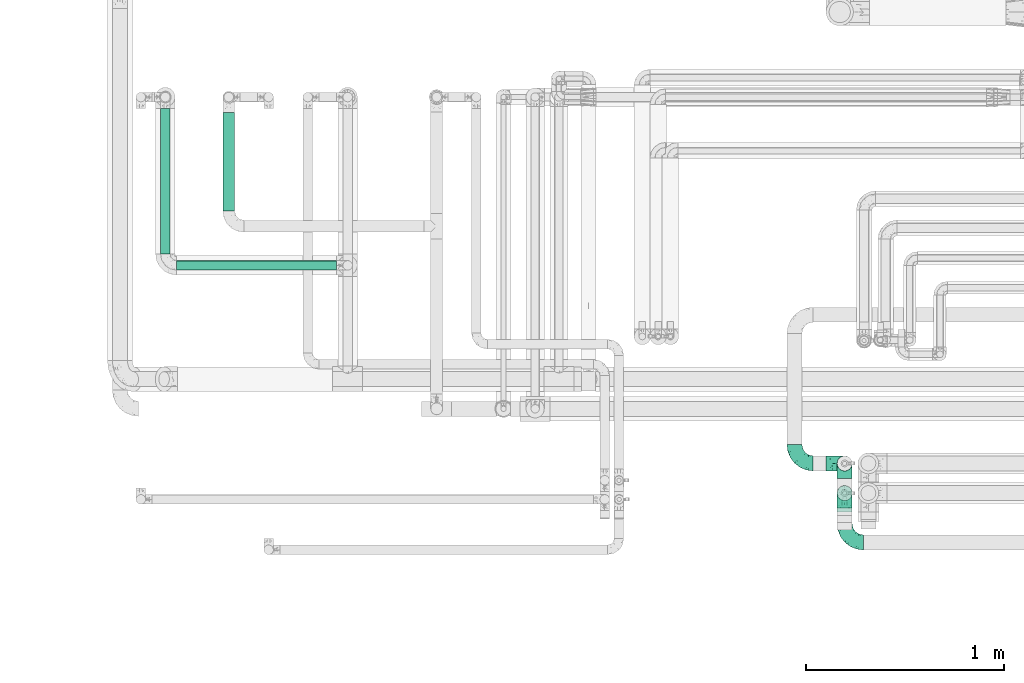
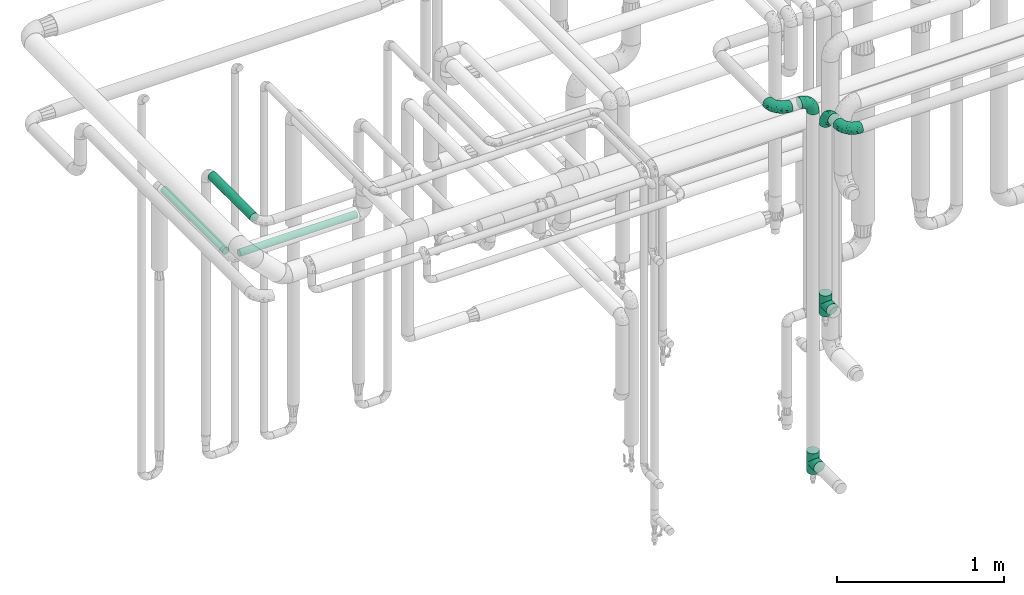
# One storey, part 694 of 827: 6 flow fittings, 3 flow segments.
"""IFC2X3 building model written with IfcOpenShell, lengths in millimetres."""

from ifc_helpers import new_model, entity, si_unit, converted_unit, derived_unit, direction, frame, origin, origin_2d_with_axis, place, context, subcontext, project, spatial, circle, extrude, faceted_brep, source, transform, mapped, material, type_object, type_shapes, element, save


model = new_model("IFC2X3")

# Units and contexts
model_context = context("Model", 3, precision=0.01, world=origin(), true_north=direction((6.12303176911189e-17, 1.0)))
body_context = subcontext(model_context, "Body", "Model", "MODEL_VIEW")
ifc_project = project(units=[si_unit("LENGTHUNIT", "METRE", prefix="MILLI"), si_unit("AREAUNIT", "SQUARE_METRE"), si_unit("VOLUMEUNIT", "CUBIC_METRE"), converted_unit("PLANEANGLEUNIT", "DEGREE", entity("IfcRatioMeasure", 0.0174532925199433), si_unit("PLANEANGLEUNIT", "RADIAN"), dimensions=[0, 0, 0, 0, 0, 0, 0]), si_unit("MASSUNIT", "GRAM", prefix="KILO"), derived_unit("MASSDENSITYUNIT", [(si_unit("MASSUNIT", "GRAM", prefix="KILO"), 1), (si_unit("LENGTHUNIT", "METRE"), -3)]), derived_unit("MOMENTOFINERTIAUNIT", [(si_unit("LENGTHUNIT", "METRE"), 4)]), si_unit("TIMEUNIT", "SECOND"), si_unit("FREQUENCYUNIT", "HERTZ"), si_unit("THERMODYNAMICTEMPERATUREUNIT", "DEGREE_CELSIUS"), derived_unit("THERMALTRANSMITTANCEUNIT", [(si_unit("MASSUNIT", "GRAM", prefix="KILO"), 1), (si_unit("THERMODYNAMICTEMPERATUREUNIT", "KELVIN"), -1), (si_unit("TIMEUNIT", "SECOND"), -3)]), derived_unit("VOLUMETRICFLOWRATEUNIT", [(si_unit("LENGTHUNIT", "METRE"), 3), (si_unit("TIMEUNIT", "SECOND"), -1)]), derived_unit("MASSFLOWRATEUNIT", [(si_unit("MASSUNIT", "GRAM", prefix="KILO"), 1), (si_unit("TIMEUNIT", "SECOND"), -1)]), derived_unit("ROTATIONALFREQUENCYUNIT", [(si_unit("TIMEUNIT", "SECOND"), -1)]), si_unit("ELECTRICCURRENTUNIT", "AMPERE"), si_unit("ELECTRICVOLTAGEUNIT", "VOLT"), si_unit("POWERUNIT", "WATT"), si_unit("FORCEUNIT", "NEWTON", prefix="KILO"), si_unit("ILLUMINANCEUNIT", "LUX"), si_unit("LUMINOUSFLUXUNIT", "LUMEN"), si_unit("LUMINOUSINTENSITYUNIT", "CANDELA"), derived_unit("USERDEFINED", [(si_unit("MASSUNIT", "GRAM", prefix="KILO"), -1), (si_unit("LENGTHUNIT", "METRE"), -2), (si_unit("TIMEUNIT", "SECOND"), 3), (si_unit("LUMINOUSFLUXUNIT", "LUMEN"), 1)]), derived_unit("LINEARVELOCITYUNIT", [(si_unit("LENGTHUNIT", "METRE"), 1), (si_unit("TIMEUNIT", "SECOND"), -1)]), si_unit("PRESSUREUNIT", "PASCAL"), derived_unit("USERDEFINED", [(si_unit("LENGTHUNIT", "METRE"), -2), (si_unit("MASSUNIT", "GRAM", prefix="KILO"), 1), (si_unit("TIMEUNIT", "SECOND"), -2)]), derived_unit("LINEARFORCEUNIT", [(si_unit("MASSUNIT", "GRAM", prefix="KILO"), 1), (si_unit("LENGTHUNIT", "METRE"), 1), (si_unit("TIMEUNIT", "SECOND"), -2), (si_unit("LENGTHUNIT", "METRE"), -1)]), derived_unit("PLANARFORCEUNIT", [(si_unit("MASSUNIT", "GRAM", prefix="KILO"), 1), (si_unit("LENGTHUNIT", "METRE"), 1), (si_unit("TIMEUNIT", "SECOND"), -2), (si_unit("LENGTHUNIT", "METRE"), -2)])], contexts=[model_context])

# Site, building, storey
site_placement = place(None, origin())
site = spatial("IfcSite", under=ifc_project, at=site_placement, CompositionType="ELEMENT")
building_placement = place(site_placement, origin())
building = spatial("IfcBuilding", under=site, at=building_placement, CompositionType="ELEMENT")
storey_placement = place(building_placement, frame((0.0, 0.0, 28200.0)))
storey = spatial("IfcBuildingStorey", under=building, at=storey_placement, Name="08", CompositionType="ELEMENT", Elevation=28200.0)

# Flow segments
pipe_segment_type = type_object("IfcPipeSegmentType", PredefinedType="NOTDEFINED")
flow_segment_1_placement = place(storey_placement, frame((52487.79, 16922.5, 2466.57)))
element("IfcFlowSegment", 1, at=flow_segment_1_placement, inside=storey, type_object=pipe_segment_type, context=body_context, shape_type="SweptSolid", body=[
    extrude(circle(Radius=30.0, at=origin_2d_with_axis()), frame((31.6, 0.0, 31.6), z_axis=(0.0, 1.0, 0.0), x_axis=(-1.0, 0.0, 0.0)), (0.0, 0.0, 1.0), 500.537174621597),
])
flow_segment_2_placement = place(storey_placement, frame((52172.68, 16705.39, 2472.57)))
element("IfcFlowSegment", 2, at=flow_segment_2_placement, inside=storey, type_object=pipe_segment_type, context=body_context, shape_type="SweptSolid", body=[
    extrude(circle(Radius=24.0, at=origin_2d_with_axis()), frame((25.6, 0.0, 25.6), z_axis=(0.0, 1.0, 0.0), x_axis=(-1.0, 0.0, 0.0)), (0.0, 0.0, 1.0), 737.613736356019),
])
flow_segment_3_placement = place(storey_placement, frame((52255.28, 16622.79, 2472.57)))
element("IfcFlowSegment", 3, at=flow_segment_3_placement, inside=storey, type_object=pipe_segment_type, context=body_context, shape_type="SweptSolid", body=[
    extrude(circle(Radius=24.0, at=origin_2d_with_axis()), frame((0.0, 25.6, 25.6), z_axis=(1.0, 0.0, 0.0), x_axis=(0.0, -1.0, 0.0)), (0.0, 0.0, 1.0), 808.780981573714),
])

# Flow fittings
ifc_material = material()
pipe_fitting_type_1 = type_object("IfcPipeFittingType", Name="ADSK_1", PredefinedType="NOTDEFINED", material=ifc_material)
shared_shape_1 = source(origin(), body_context, "Body", "Brep", [
    faceted_brep([(-95.0, 19.02, -32.95), (-95.0, 9.85, -36.75), (-95.0, 0.0, -38.05), (-95.0, -9.85, -36.75), (-95.0, -19.03, -32.95), (-95.0, -26.91, -26.91), (-95.0, -32.95, -19.03), (-95.0, -36.75, -9.85), (-95.0, -38.05, 0.0), (-95.0, -36.75, 9.85), (-95.0, -32.95, 19.02), (-95.0, -26.91, 26.91), (-95.0, -19.03, 32.95), (-95.0, -9.85, 36.75), (-95.0, 0.0, 38.05), (-95.0, 9.85, 36.75), (-95.0, 19.02, 32.95), (-95.0, 26.91, 26.91), (-95.0, 32.95, 19.02), (-95.0, 36.75, 9.85), (-95.0, 38.05, 0.0), (-95.0, 36.75, -9.85), (-95.0, 32.95, -19.03), (-95.0, 26.91, -26.91), (0.0, 95.0, -38.05), (-9.85, 95.0, -36.75), (-19.02, 95.0, -32.95), (-26.91, 95.0, -26.91), (-32.95, 95.0, -19.03), (-36.75, 95.0, -9.85), (-38.05, 95.0, 0.0), (-36.75, 95.0, 9.85), (-32.95, 95.0, 19.02), (-26.91, 95.0, 26.91), (-19.02, 95.0, 32.95), (-9.85, 95.0, 36.75), (0.0, 95.0, 38.05), (9.85, 95.0, 36.75), (19.03, 95.0, 32.95), (26.91, 95.0, 26.91), (32.95, 95.0, 19.02), (36.75, 95.0, 9.85), (38.05, 95.0, 0.0), (36.75, 95.0, -9.85), (32.95, 95.0, -19.03), (26.91, 95.0, -26.91), (19.03, 95.0, -32.95), (9.85, 95.0, -36.75), (-7.99, -4.96, 6.3), (-0.92, 0.92, 0.0), (4.62, 8.1, 8.01), (-76.19, -35.57, 0.0), (-64.32, -32.32, 12.43), (20.51, 62.45, 28.68), (-60.56, -33.52, 0.0), (-70.4, -13.47, 34.42), (-39.61, -5.88, 32.32), (-49.6, 2.07, 37.1), (-70.34, -28.81, 21.71), (14.64, 40.81, 26.5), (5.88, 39.61, 32.32), (3.59, 20.77, 25.31), (-40.45, 68.06, 16.75), (-62.45, -20.51, 28.68), (-44.52, -26.87, 0.0), (-28.47, -20.22, 0.0), (-26.43, -17.83, 8.75), (-76.1, 39.63, 10.76), (-72.74, 37.58, 18.19), (-60.35, 46.18, 14.61), (-13.4, 13.4, 32.12), (-20.77, -3.59, 25.31), (-14.66, 81.47, 35.56), (-6.22, 71.26, 37.92), (-57.5, 42.48, 22.79), (-15.0, 34.74, 37.7), (-27.1, 12.08, 36.05), (-9.2, 28.81, 35.63), (-79.98, 23.7, 30.95), (-73.68, -4.3, 37.48), (-30.74, 21.67, 37.97), (-62.36, 47.59, 6.79), (-72.71, 32.83, 24.69), (-67.42, 7.02, 37.95), (-32.13, 75.27, 24.51), (-43.46, 51.47, 26.26), (-24.98, 73.15, 31.29), (20.59, 41.28, 19.85), (7.79, 16.09, 15.86), (-73.21, 42.39, 0.0), (-54.73, 54.73, 0.0), (-73.44, 15.79, 35.79), (-5.94, 4.32, 20.43), (28.81, 70.34, 21.71), (32.32, 64.32, 12.43), (-53.59, 26.2, 35.09), (-52.02, 19.31, 37.21), (21.38, 33.53, 10.34), (26.87, 44.52, 0.0), (-48.28, 12.14, 38.05), (4.3, 73.68, 37.48), (-44.08, -25.52, 12.79), (-41.28, -20.59, 19.85), (35.57, 76.19, 0.0), (-47.26, 54.3, 20.18), (-47.4, 61.99, 8.58), (-42.39, 73.21, 0.0), (-39.67, 78.86, 7.21), (-45.69, 36.84, 33.11), (-32.83, 50.13, 33.35), (13.47, 70.4, 34.42), (-18.25, 63.73, 36.07), (-40.63, -13.75, 27.22), (-16.63, 46.37, 37.95), (-53.47, 38.79, 28.59), (-26.07, 48.54, 36.15), (-34.51, 34.51, 36.86), (-2.07, 49.6, 37.1), (-22.79, -10.49, 19.23), (-61.73, 28.67, 31.87), (9.65, 14.7, 0.0), (20.22, 28.47, 0.0), (33.52, 60.56, 0.0), (-11.42, -5.44, 13.25), (-14.7, -9.65, 0.0), (-81.47, 14.66, -35.56), (-62.45, -20.51, -28.68), (-71.26, 6.22, -37.92), (-75.27, 32.13, -24.51), (-73.15, 24.98, -31.29), (13.47, 70.4, -34.42), (5.88, 39.61, -32.32), (-2.07, 49.6, -37.1), (-78.86, 39.67, -7.21), (-70.4, -13.47, -34.42), (-39.61, -5.88, -32.32), (-61.99, 47.4, -8.58), (32.32, 64.32, -12.43), (28.81, 70.34, -21.71), (-63.73, 18.25, -36.07), (-50.13, 32.83, -33.35), (4.3, 73.68, -37.48), (-7.02, 67.42, -37.95), (-39.63, 76.1, -10.76), (-46.18, 60.35, -14.61), (-47.59, 62.36, -6.79), (-64.32, -32.32, -12.43), (-26.2, 53.59, -35.09), (-15.79, 73.44, -35.79), (-19.31, 52.02, -37.21), (-37.58, 72.74, -18.19), (-70.34, -28.81, -21.71), (-42.48, 57.5, -22.79), (-38.79, 53.47, -28.59), (-51.47, 43.46, -26.26), (-32.83, 72.71, -24.69), (-46.37, 16.63, -37.95), (-73.68, -4.3, -37.48), (-41.28, -20.59, -19.85), (-44.08, -25.52, -12.79), (13.75, 40.63, -27.22), (20.51, 62.45, -28.68), (-68.06, 40.45, -16.75), (-54.3, 47.26, -20.18), (-12.14, 48.28, -38.05), (-21.67, 30.74, -37.97), (-36.84, 45.69, -33.11), (-11.42, -5.44, -13.25), (7.79, 16.09, -15.86), (4.62, 8.1, -8.01), (-23.7, 79.98, -30.95), (-26.43, -17.83, -8.75), (-7.99, -4.96, -6.3), (-40.81, -14.64, -26.5), (-20.77, -3.59, -25.31), (-34.74, 15.0, -37.7), (-12.08, 27.1, -36.05), (-28.81, 9.2, -35.63), (-22.79, -10.49, -19.23), (21.38, 33.53, -10.34), (20.59, 41.28, -19.85), (-48.54, 26.07, -36.15), (-49.6, 2.07, -37.1), (-13.4, 13.4, -32.12), (3.59, 20.77, -25.31), (-28.67, 61.73, -31.87), (-34.51, 34.51, -36.86), (-5.94, 4.32, -20.43)], [[[0, 1, 2, 3, 4, 5, 6, 7, 8, 9, 10, 11, 12, 13, 14, 15, 16, 17, 18, 19, 20, 21, 22, 23]], [[24, 25, 26, 27, 28, 29, 30, 31, 32, 33, 34, 35, 36, 37, 38, 39, 40, 41, 42, 43, 44, 45, 46, 47]], [[48, 49, 50]], [[51, 52, 9]], [[53, 39, 38]], [[9, 52, 10]], [[54, 52, 51]], [[55, 56, 57]], [[11, 10, 58]], [[59, 60, 61]], [[32, 31, 62]], [[63, 12, 11]], [[63, 55, 12]], [[64, 65, 66]], [[67, 68, 69]], [[70, 56, 71]], [[35, 72, 73]], [[69, 68, 74]], [[75, 76, 77]], [[16, 78, 17]], [[13, 79, 14]], [[76, 75, 80]], [[67, 69, 81]], [[18, 17, 82]], [[14, 79, 83]], [[20, 19, 67]], [[84, 85, 86]], [[87, 61, 88]], [[89, 81, 90]], [[18, 82, 68]], [[15, 91, 16]], [[14, 83, 15]], [[71, 92, 61]], [[17, 78, 82]], [[93, 87, 94]], [[95, 91, 96]], [[97, 98, 94]], [[86, 72, 34]], [[96, 99, 80]], [[37, 36, 100]], [[40, 39, 93]], [[40, 94, 41]], [[64, 66, 101]], [[93, 94, 40]], [[58, 102, 63]], [[94, 103, 41]], [[94, 87, 97]], [[104, 69, 74]], [[34, 33, 86]], [[105, 69, 104]], [[52, 58, 10]], [[106, 107, 30]], [[108, 109, 85]], [[105, 106, 90]], [[53, 110, 60]], [[86, 111, 72]], [[86, 109, 111]], [[33, 84, 86]], [[12, 55, 13]], [[112, 56, 63]], [[110, 38, 37]], [[34, 72, 35]], [[36, 35, 73]], [[111, 113, 73]], [[105, 107, 106]], [[110, 53, 38]], [[74, 114, 85]], [[91, 15, 83]], [[105, 90, 81]], [[107, 62, 31]], [[33, 32, 84]], [[115, 109, 116]], [[111, 115, 113]], [[100, 73, 117]], [[56, 55, 63]], [[79, 55, 57]], [[102, 118, 112]], [[56, 70, 76]], [[100, 110, 37]], [[117, 77, 60]], [[117, 60, 110]], [[60, 70, 61]], [[58, 52, 101]], [[63, 11, 58]], [[39, 53, 93]], [[87, 93, 53]], [[96, 91, 83]], [[78, 91, 119]], [[32, 62, 84]], [[84, 62, 104]], [[86, 85, 109]], [[85, 114, 108]], [[80, 113, 116]], [[117, 73, 113]], [[80, 116, 96]], [[80, 57, 76]], [[71, 112, 118]], [[61, 87, 59]], [[62, 107, 105]], [[97, 120, 121]], [[70, 71, 61]], [[71, 118, 92]], [[73, 100, 36]], [[110, 100, 117]], [[55, 79, 13]], [[83, 79, 57]], [[96, 83, 99]], [[116, 108, 95]], [[50, 97, 88]], [[97, 87, 88]], [[50, 49, 120]], [[122, 94, 98]], [[89, 20, 67]], [[105, 81, 69]], [[89, 67, 81]], [[68, 19, 18]], [[68, 67, 19]], [[74, 68, 82]], [[114, 82, 119]], [[74, 85, 104]], [[82, 114, 74]], [[114, 119, 108]], [[95, 108, 119]], [[116, 109, 108]], [[123, 48, 50]], [[97, 50, 120]], [[123, 50, 88]], [[91, 95, 119]], [[116, 95, 96]], [[84, 104, 85]], [[104, 62, 105]], [[83, 57, 99]], [[57, 80, 99]], [[66, 48, 123]], [[66, 124, 48]], [[118, 66, 123]], [[124, 66, 65]], [[66, 118, 101]], [[54, 64, 52]], [[124, 49, 48]], [[30, 107, 31]], [[91, 78, 16]], [[82, 78, 119]], [[56, 76, 57]], [[77, 76, 70]], [[60, 77, 70]], [[77, 117, 75]], [[117, 113, 75]], [[113, 80, 75]], [[9, 8, 51]], [[103, 94, 122]], [[103, 42, 41]], [[73, 72, 111]], [[113, 115, 116]], [[111, 109, 115]], [[102, 112, 63]], [[71, 56, 112]], [[118, 102, 101]], [[92, 123, 88]], [[123, 92, 118]], [[61, 92, 88]], [[87, 53, 59]], [[60, 59, 53]], [[97, 121, 98]], [[58, 101, 102]], [[64, 101, 52]], [[125, 1, 0]], [[126, 5, 4]], [[2, 1, 127]], [[1, 125, 127]], [[128, 129, 23]], [[130, 131, 132]], [[89, 133, 20]], [[126, 134, 135]], [[136, 89, 90]], [[137, 138, 44]], [[139, 129, 140]], [[24, 141, 142]], [[143, 144, 145]], [[125, 129, 139]], [[6, 146, 7]], [[147, 148, 149]], [[146, 51, 7]], [[143, 150, 144]], [[146, 6, 151]], [[152, 153, 154]], [[126, 4, 134]], [[0, 23, 129]], [[28, 155, 150]], [[43, 42, 103]], [[54, 146, 64]], [[139, 156, 127]], [[157, 3, 2]], [[151, 158, 159]], [[160, 131, 161]], [[22, 21, 162]], [[136, 144, 163]], [[149, 164, 165]], [[24, 142, 25]], [[166, 140, 154]], [[154, 129, 128]], [[143, 30, 29]], [[167, 168, 169]], [[155, 28, 27]], [[26, 170, 27]], [[171, 167, 172]], [[26, 25, 148]], [[27, 170, 155]], [[173, 135, 174]], [[144, 150, 152]], [[175, 176, 177]], [[24, 47, 141]], [[45, 161, 46]], [[148, 25, 142]], [[176, 175, 165]], [[64, 159, 171]], [[138, 45, 44]], [[130, 46, 161]], [[137, 44, 43]], [[178, 159, 158]], [[137, 103, 122]], [[163, 144, 152]], [[136, 133, 89]], [[103, 137, 43]], [[6, 5, 151]], [[178, 158, 173]], [[134, 4, 3]], [[178, 173, 174]], [[137, 98, 179]], [[145, 90, 106]], [[138, 180, 161]], [[46, 130, 47]], [[136, 90, 145]], [[133, 162, 21]], [[23, 22, 128]], [[139, 140, 181]], [[139, 181, 156]], [[157, 127, 182]], [[157, 134, 3]], [[182, 177, 135]], [[182, 135, 134]], [[135, 183, 174]], [[131, 130, 161]], [[141, 130, 132]], [[160, 180, 184]], [[131, 183, 176]], [[5, 126, 151]], [[158, 151, 126]], [[180, 138, 137]], [[161, 45, 138]], [[149, 148, 142]], [[170, 148, 185]], [[22, 162, 128]], [[128, 162, 163]], [[129, 154, 140]], [[154, 153, 166]], [[165, 156, 186]], [[182, 127, 156]], [[165, 186, 149]], [[165, 132, 176]], [[131, 184, 183]], [[187, 167, 178]], [[184, 168, 187]], [[167, 169, 172]], [[184, 180, 168]], [[174, 183, 184]], [[127, 157, 2]], [[134, 157, 182]], [[130, 141, 47]], [[142, 141, 132]], [[149, 142, 164]], [[186, 166, 147]], [[180, 179, 168]], [[169, 179, 120]], [[137, 179, 180]], [[179, 121, 120]], [[106, 30, 143]], [[136, 145, 144]], [[106, 143, 145]], [[150, 29, 28]], [[150, 143, 29]], [[152, 150, 155]], [[153, 155, 185]], [[152, 154, 163]], [[155, 153, 152]], [[153, 185, 166]], [[147, 166, 185]], [[186, 140, 166]], [[169, 120, 49]], [[169, 49, 172]], [[179, 169, 168]], [[148, 147, 185]], [[186, 147, 149]], [[128, 163, 154]], [[163, 162, 136]], [[142, 132, 164]], [[132, 165, 164]], [[171, 124, 65]], [[124, 171, 172]], [[64, 146, 159]], [[171, 159, 178]], [[171, 65, 64]], [[172, 49, 124]], [[162, 133, 136]], [[20, 133, 21]], [[148, 170, 26]], [[155, 170, 185]], [[131, 176, 132]], [[177, 176, 183]], [[135, 177, 183]], [[177, 182, 175]], [[182, 156, 175]], [[156, 165, 175]], [[51, 146, 54]], [[51, 8, 7]], [[129, 125, 0]], [[127, 125, 139]], [[140, 186, 181]], [[156, 181, 186]], [[158, 126, 173]], [[135, 173, 126]], [[187, 178, 174]], [[171, 178, 167]], [[184, 187, 174]], [[167, 187, 168]], [[180, 160, 161]], [[184, 131, 160]], [[98, 137, 122]], [[98, 121, 179]], [[151, 159, 146]]]),
])
type_shapes(pipe_fitting_type_1, [shared_shape_1])
for number, where, z_axis, x_axis, name in (
    (4, (55635.84, 15246.2, 3050.0), (0.0, 0.0, 1.0), (0.0, -1.0, 0.0), "ADSK_1"),
    (5, (55635.84, 15646.2, 3050.0), (0.0, -1.0, 0.0), (0.0, 0.0, 1.0), "ADSK_1"),
    (6, (55381.84, 15646.2, 3050.0), (0.0, 0.0, 1.0), (0.0, -1.0, 0.0), "ADSK_1"),
    (7, (55635.84, 15496.2, 3050.0), (-1.0, 0.0, 0.0), (0.0, 1.0, 0.0), "ADSK_1"),
):
    element("IfcFlowFitting", number, at=place(storey_placement, frame(where, z_axis=z_axis, x_axis=x_axis)), inside=storey, type_object=pipe_fitting_type_1, material=ifc_material, Name=name, ObjectType="ADSK_1", context=body_context, shape_type="MappedRepresentation", body=[
        mapped(shared_shape_1, transform((0.0, 0.0, 0.0), scale=1.0)),
    ])
pipe_fitting_type_2 = type_object("IfcPipeFittingType", Name="ADSK_1", PredefinedType="NOTDEFINED", material=ifc_material)
shared_shape_2 = source(origin(), body_context, "Body", "Brep", [
    faceted_brep([(-76.0, 9.85, -36.75), (-76.0, 0.0, -38.05), (-76.0, -9.85, -36.75), (-76.0, -19.03, -32.95), (-76.0, -22.97, -29.93), (-76.0, -26.91, -26.91), (-76.0, -29.93, -22.97), (-76.0, -32.95, -19.03), (-76.0, -34.85, -14.44), (-76.0, -36.75, -9.85), (-76.0, -38.05, 0.0), (-76.0, -36.75, 9.85), (-76.0, -34.85, 14.44), (-76.0, -32.95, 19.02), (-76.0, -29.93, 22.97), (-76.0, -26.91, 26.91), (-76.0, -22.97, 29.93), (-76.0, -19.03, 32.95), (-76.0, -9.85, 36.75), (-76.0, 0.0, 38.05), (-76.0, 9.85, 36.75), (-76.0, 19.02, 32.95), (-76.0, 26.91, 26.91), (-76.0, 32.95, 19.02), (-76.0, 36.75, 9.85), (-76.0, 38.05, 0.0), (-76.0, 36.75, -9.85), (-76.0, 32.95, -19.03), (-76.0, 26.91, -26.91), (-76.0, 19.02, -32.95), (76.0, 26.91, -26.91), (76.0, 32.95, -19.03), (76.0, 36.75, -9.85), (76.0, 38.05, 0.0), (76.0, 36.75, 9.85), (76.0, 32.95, 19.02), (76.0, 26.91, 26.91), (76.0, 19.02, 32.95), (76.0, 9.85, 36.75), (76.0, 0.0, 38.05), (76.0, -9.85, 36.75), (76.0, -19.03, 32.95), (76.0, -22.97, 29.93), (76.0, -26.91, 26.91), (76.0, -29.93, 22.97), (76.0, -32.95, 19.02), (76.0, -34.85, 14.44), (76.0, -36.75, 9.85), (76.0, -38.05, 0.0), (76.0, -36.75, -9.85), (76.0, -34.85, -14.44), (76.0, -32.95, -19.03), (76.0, -29.93, -22.97), (76.0, -26.91, -26.91), (76.0, -22.97, -29.93), (76.0, -19.03, -32.95), (76.0, -9.85, -36.75), (76.0, 0.0, -38.05), (76.0, 9.85, -36.75), (76.0, 19.02, -32.95), (36.99, -36.99, 8.94), (38.05, -38.05, 0.0), (-36.99, -36.99, 8.94), (-38.05, -38.05, 0.0), (35.51, -35.51, 12.97), (34.04, -34.04, 17.0), (18.81, -18.81, 33.08), (29.74, -29.74, 23.73), (24.56, -24.56, 29.06), (-35.51, -35.51, 12.97), (-34.04, -34.04, 17.0), (-18.81, -18.81, 33.08), (-29.74, -29.74, 23.73), (-24.56, -24.56, 29.06), (-12.7, -12.7, 35.87), (6.4, -6.4, 37.51), (12.7, -12.7, 35.87), (0.0, 0.0, 38.05), (-6.4, -6.4, 37.51), (6.4, -6.4, -37.51), (0.0, 0.0, -38.05), (12.7, -12.7, -35.87), (-24.56, -24.56, -29.06), (-6.4, -6.4, -37.51), (-35.51, -35.51, -12.97), (-36.99, -36.99, -8.94), (-29.74, -29.74, -23.73), (-12.7, -12.7, -35.87), (18.81, -18.81, -33.08), (24.56, -24.56, -29.06), (-34.04, -34.04, -17.0), (29.74, -29.74, -23.73), (36.99, -36.99, -8.94), (35.51, -35.51, -12.97), (34.04, -34.04, -17.0), (-18.81, -18.81, -33.08), (9.85, -76.0, -36.75), (19.03, -76.0, -32.95), (26.91, -76.0, -26.91), (32.95, -76.0, -19.03), (36.75, -76.0, -9.85), (38.05, -76.0, 0.0), (36.75, -76.0, 9.85), (32.95, -76.0, 19.02), (26.91, -76.0, 26.91), (19.03, -76.0, 32.95), (9.85, -76.0, 36.75), (0.0, -76.0, 38.05), (-9.85, -76.0, 36.75), (-19.02, -76.0, 32.95), (-26.91, -76.0, 26.91), (-32.95, -76.0, 19.02), (-36.75, -76.0, 9.85), (-38.05, -76.0, 0.0), (-36.75, -76.0, -9.85), (-32.95, -76.0, -19.03), (-26.91, -76.0, -26.91), (-19.02, -76.0, -32.95), (-9.85, -76.0, -36.75), (0.0, -76.0, -38.05)], [[[0, 1, 2, 3, 4, 5, 6, 7, 8, 9, 10, 11, 12, 13, 14, 15, 16, 17, 18, 19, 20, 21, 22, 23, 24, 25, 26, 27, 28, 29]], [[30, 31, 32, 33, 34, 35, 36, 37, 38, 39, 40, 41, 42, 43, 44, 45, 46, 47, 48, 49, 50, 51, 52, 53, 54, 55, 56, 57, 58, 59]], [[48, 47, 60]], [[60, 61, 48]], [[62, 10, 63]], [[47, 46, 64]], [[46, 45, 65]], [[41, 66, 42]], [[43, 67, 45, 44]], [[67, 43, 68]], [[45, 67, 65]], [[68, 43, 42]], [[11, 69, 12]], [[70, 12, 69]], [[10, 62, 11]], [[11, 62, 69]], [[71, 17, 16]], [[72, 73, 15]], [[72, 15, 14, 13]], [[15, 73, 16]], [[71, 74, 17]], [[72, 13, 70]], [[46, 65, 64]], [[42, 66, 68]], [[40, 39, 75]], [[47, 64, 60]], [[66, 41, 76]], [[75, 76, 40]], [[75, 39, 77]], [[78, 77, 19]], [[76, 41, 40]], [[23, 22, 36, 35]], [[24, 23, 35, 34]], [[21, 20, 38, 37]], [[22, 21, 37, 36]], [[38, 20, 19, 77, 39]], [[25, 24, 34, 33]], [[70, 13, 12]], [[78, 18, 74]], [[18, 78, 19]], [[18, 17, 74]], [[71, 16, 73]], [[28, 27, 31, 30]], [[26, 32, 31, 27]], [[25, 33, 32, 26]], [[29, 28, 30, 59]], [[57, 56, 79]], [[58, 57, 80, 1, 0]], [[79, 56, 81]], [[82, 5, 4]], [[59, 58, 0, 29]], [[56, 55, 81]], [[57, 79, 80]], [[80, 83, 1]], [[9, 84, 85]], [[86, 7, 6, 5]], [[83, 87, 2]], [[1, 83, 2]], [[87, 3, 2]], [[88, 54, 89]], [[54, 53, 89]], [[8, 90, 84]], [[88, 55, 54]], [[91, 89, 53]], [[52, 51, 91, 53]], [[55, 88, 81]], [[49, 92, 93]], [[92, 49, 48]], [[94, 50, 93]], [[61, 92, 48]], [[85, 63, 10]], [[51, 94, 91]], [[82, 4, 95]], [[49, 93, 50]], [[4, 3, 95]], [[5, 82, 86]], [[94, 51, 50]], [[95, 3, 87]], [[9, 8, 84]], [[90, 8, 7]], [[9, 85, 10]], [[90, 7, 86]], [[96, 97, 98, 99, 100, 101, 102, 103, 104, 105, 106, 107, 108, 109, 110, 111, 112, 113, 114, 115, 116, 117, 118, 119]], [[62, 63, 113]], [[112, 62, 113]], [[110, 109, 73]], [[72, 111, 110]], [[70, 112, 111]], [[74, 109, 108]], [[112, 70, 69, 62]], [[73, 72, 110]], [[70, 111, 72]], [[74, 71, 109]], [[107, 77, 78]], [[74, 108, 78]], [[73, 109, 71]], [[78, 108, 107]], [[75, 107, 106]], [[105, 76, 106]], [[103, 102, 65]], [[67, 104, 103]], [[68, 105, 104]], [[60, 102, 101]], [[68, 66, 105]], [[76, 75, 106]], [[66, 76, 105]], [[61, 60, 101]], [[65, 67, 103]], [[102, 60, 64, 65]], [[68, 104, 67]], [[107, 75, 77]], [[61, 101, 92]], [[100, 92, 101]], [[98, 97, 89]], [[94, 100, 99]], [[98, 91, 99]], [[81, 97, 96]], [[100, 94, 93, 92]], [[89, 91, 98]], [[94, 99, 91]], [[81, 88, 97]], [[119, 80, 79]], [[81, 96, 79]], [[89, 97, 88]], [[79, 96, 119]], [[83, 119, 118]], [[117, 87, 118]], [[115, 114, 90]], [[86, 116, 115]], [[82, 117, 116]], [[85, 114, 113]], [[82, 95, 117]], [[87, 83, 118]], [[95, 87, 117]], [[63, 85, 113]], [[90, 86, 115]], [[114, 85, 84, 90]], [[82, 116, 86]], [[119, 83, 80]]]),
])
type_shapes(pipe_fitting_type_2, [shared_shape_2])
for number, where, z_axis, x_axis, name in (
    (8, (55635.84, 15646.2, 408.5), (1.0, 0.0, 0.0), (0.0, 0.0, -1.0), "ADSK_1"),
    (9, (55635.84, 15496.2, 1649.5), (1.0, 0.0, 0.0), (0.0, 0.0, -1.0), "ADSK_1"),
):
    element("IfcFlowFitting", number, at=place(storey_placement, frame(where, z_axis=z_axis, x_axis=x_axis)), inside=storey, type_object=pipe_fitting_type_2, material=ifc_material, Name=name, ObjectType="ADSK_1", context=body_context, shape_type="MappedRepresentation", body=[
        mapped(shared_shape_2, transform((0.0, 0.0, 0.0), scale=1.0)),
    ])

save(model, "model.ifc")
